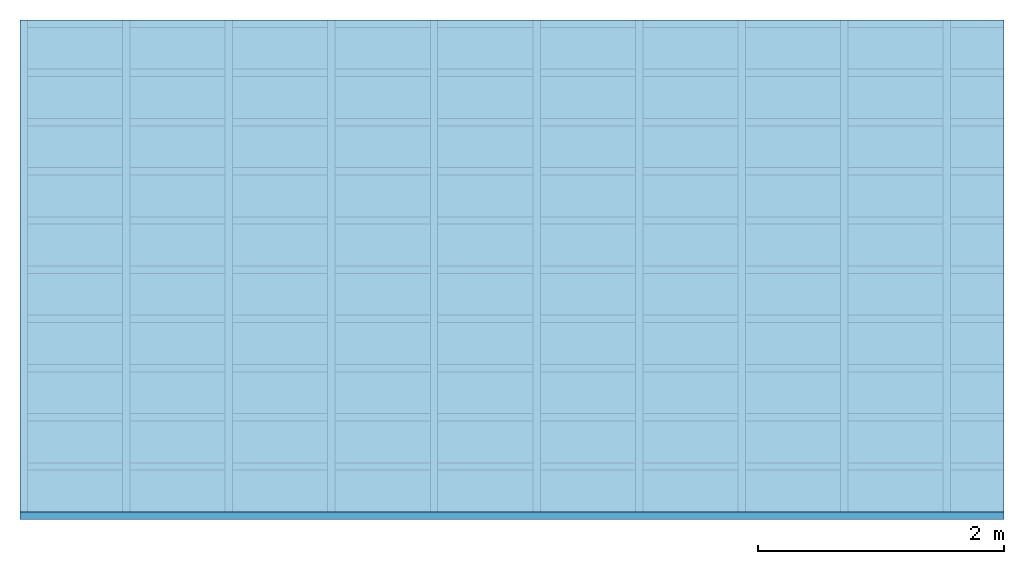
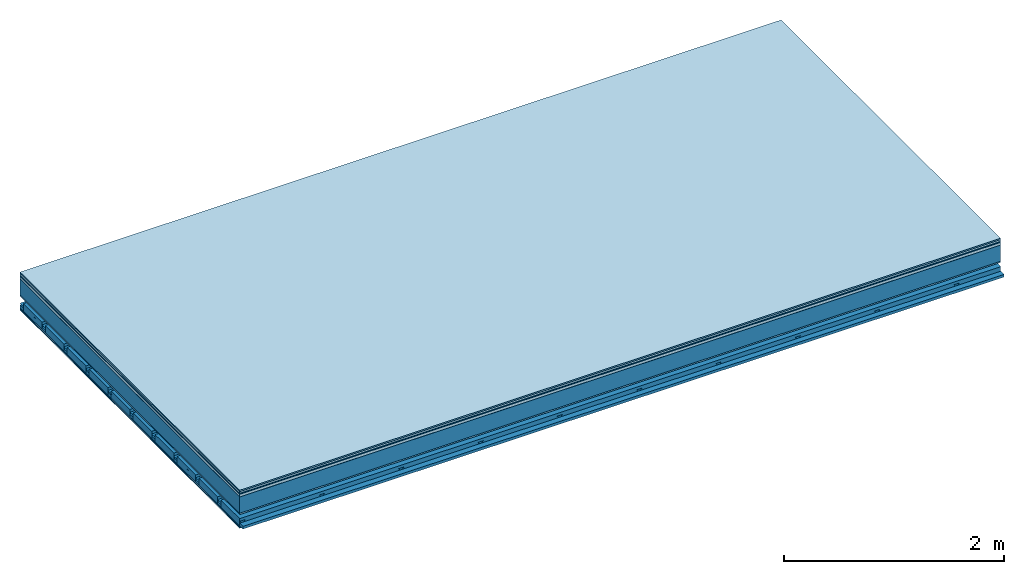
# One storey: 9 plates, 4 members, 1 element without a shape of its own.
"""IFC4 building model written with IfcOpenShell, lengths in metres."""

from ifc_helpers import new_model, si_unit, derived_unit, direction, frame, frame_2d, origin, origin_with_axes, place, context, project, spatial, polyline, rectangle, outline, extrude, material, layer, layer_set, type_object, element, aggregate, save


model = new_model("IFC4")

# Units and contexts
plan_context = context("Plan", 3, precision=1e-05, world=origin(), true_north=direction((0.0, 1.0)))
model_context = context("Model", 3, precision=1e-05, world=origin(), true_north=direction((0.0, 1.0)))
ifc_project = project(units=[si_unit("LENGTHUNIT", "METRE"), derived_unit("SOUNDPRESSUREUNIT", [(si_unit("PRESSUREUNIT", "PASCAL", prefix="MICRO"), 0)]), si_unit("ENERGYUNIT", "JOULE", prefix="MEGA"), si_unit("MASSUNIT", "GRAM", prefix="KILO"), derived_unit("THERMALTRANSMITTANCEUNIT", [(si_unit("POWERUNIT", "WATT"), 1), (si_unit("AREAUNIT", "SQUARE_METRE"), -1), (si_unit("THERMODYNAMICTEMPERATUREUNIT", "KELVIN"), -1)]), derived_unit("AREADENSITYUNIT", [(si_unit("MASSUNIT", "GRAM", prefix="KILO"), 1), (si_unit("AREAUNIT", "SQUARE_METRE"), -1)]), derived_unit("USERDEFINED", [(si_unit("ENERGYUNIT", "JOULE", prefix="MEGA"), 1), (si_unit("AREAUNIT", "SQUARE_METRE"), -1)])], contexts=[plan_context, model_context])

# Site, building, storey
site = spatial("IfcSite", under=ifc_project)
building_placement = place(None, origin())
building = spatial("IfcBuilding", under=site, at=building_placement)
storey_placement = place(building_placement, origin())
storey = spatial("IfcBuildingStorey", under=building, at=storey_placement)

# Slab, members, plates
ifc_material_1 = material(Category="11.013")
ifc_layer_1 = layer(ifc_material_1, 0.015, Name="Flooring")
ifc_material_2 = material(Category="03.007")
ifc_layer_2 = layer(ifc_material_2, 0.02, Name="On-material")
ifc_material_3 = material(Name="Wood fiber generic product", Category="10.009")
ifc_layer_3 = layer(ifc_material_3, 0.01, Name="Impact sound insulation")
ifc_material_4 = material(Name="with broken")
ifc_layer_4 = layer(ifc_material_4, 0.03, Name="on Supporting structure")
ifc_material_5 = material(Name="protection", Category="09.007")
ifc_layer_5 = layer(ifc_material_5, 0.0005, Name="Sub-floor")
ifc_material_6 = material(Name="no composite action")
ifc_layer_6 = layer(ifc_material_6, 0.0, Name="Bond")
ifc_layer_7 = layer(None, 0.18, Name="Supporting structure")
ifc_material_7 = material(Name="of the art")
ifc_layer_8 = layer(ifc_material_7, 0.0, Name="Bond")
ifc_layer_9 = layer(ifc_material_2, 0.015, Name="Lower layer 1")
ifc_layer_10 = layer(None, 0.095, Name="Coupling")
ifc_layer_11 = layer(None, 0.03, Name="Battens / profiles")
ifc_material_8 = material(Name="Plasterboard type A", Category="03.008")
ifc_layer_12 = layer(ifc_material_8, 0.0125, Name="Ceiling covering 1st layer")
ifc_layer_13 = layer(ifc_material_8, 0.0125, Name="Ceiling covering layer 2")
ifc_material_9 = material(Category="04.001")
ifc_layer_14 = layer(ifc_material_9, 0.003, Name="Surface / treatment")
ifc_layer_set = layer_set([ifc_layer_1, ifc_layer_2, ifc_layer_3, ifc_layer_4, ifc_layer_5, ifc_layer_6, ifc_layer_7, ifc_layer_8, ifc_layer_9, ifc_layer_10, ifc_layer_11, ifc_layer_12, ifc_layer_13, ifc_layer_14])
slab_type = type_object("IfcSlabType", Name="A2126", PredefinedType="NOTDEFINED", material=ifc_layer_set)
slab_placement = place(None, frame((0.0, 0.0, 0.0), z_axis=(0.0, 0.0, -1.0), x_axis=(1.0, 0.0, 0.0)))
slab = element("IfcSlab", 1, at=slab_placement, inside=storey, type_object=slab_type, material=ifc_layer_set, Name="Slab #1")
ifc_material_10 = material(Name="Solid timber panel")
member_1_placement = place(slab_placement, origin())
member_1 = element("IfcMember", 2, at=member_1_placement, material=ifc_material_10, Name="Supporting structure", context=plan_context, shape_type="SweptSolid", body=[
    extrude(rectangle(XDim=1.0, YDim=0.18, at=frame_2d((0.5, 0.09), x_axis=(1.0, 0.0))), frame((0.0, 4.0, 0.0755), z_axis=(0.0, -1.0, 0.0), x_axis=(1.0, 0.0, 0.0)), (0.0, 0.0, 1.0), 4.0),
    extrude(rectangle(XDim=1.0, YDim=0.18, at=frame_2d((0.5, 0.09), x_axis=(1.0, 0.0))), frame((1.0, 4.0, 0.0755), z_axis=(0.0, -1.0, 0.0), x_axis=(1.0, 0.0, 0.0)), (0.0, 0.0, 1.0), 4.0),
    extrude(rectangle(XDim=1.0, YDim=0.18, at=frame_2d((0.5, 0.09), x_axis=(1.0, 0.0))), frame((2.0, 4.0, 0.0755), z_axis=(0.0, -1.0, 0.0), x_axis=(1.0, 0.0, 0.0)), (0.0, 0.0, 1.0), 4.0),
    extrude(rectangle(XDim=1.0, YDim=0.18, at=frame_2d((0.5, 0.09), x_axis=(1.0, 0.0))), frame((3.0, 4.0, 0.0755), z_axis=(0.0, -1.0, 0.0), x_axis=(1.0, 0.0, 0.0)), (0.0, 0.0, 1.0), 4.0),
    extrude(rectangle(XDim=1.0, YDim=0.18, at=frame_2d((0.5, 0.09), x_axis=(1.0, 0.0))), frame((4.0, 4.0, 0.0755), z_axis=(0.0, -1.0, 0.0), x_axis=(1.0, 0.0, 0.0)), (0.0, 0.0, 1.0), 4.0),
    extrude(rectangle(XDim=1.0, YDim=0.18, at=frame_2d((0.5, 0.09), x_axis=(1.0, 0.0))), frame((5.0, 4.0, 0.0755), z_axis=(0.0, -1.0, 0.0), x_axis=(1.0, 0.0, 0.0)), (0.0, 0.0, 1.0), 4.0),
    extrude(rectangle(XDim=1.0, YDim=0.18, at=frame_2d((0.5, 0.09), x_axis=(1.0, 0.0))), frame((6.0, 4.0, 0.0755), z_axis=(0.0, -1.0, 0.0), x_axis=(1.0, 0.0, 0.0)), (0.0, 0.0, 1.0), 4.0),
    extrude(rectangle(XDim=1.0, YDim=0.18, at=frame_2d((0.5, 0.09), x_axis=(1.0, 0.0))), frame((7.0, 4.0, 0.0755), z_axis=(0.0, -1.0, 0.0), x_axis=(1.0, 0.0, 0.0)), (0.0, 0.0, 1.0), 4.0),
])
ifc_material_11 = material()
member_2_placement = place(slab_placement, origin())
member_2 = element("IfcMember", 3, at=member_2_placement, material=ifc_material_11, Name="Coupling", context=plan_context, shape_type="SweptSolid", body=[
    extrude(outline(polyline([(0.0, 0.0), (0.06, 0.0), (0.04, 0.02), (0.02, 0.02), (0.0, 0.0)])), frame((0.0, 4.0, 0.3455), z_axis=(0.0, -1.0, 0.0), x_axis=(1.0, 0.0, 0.0)), (0.0, 0.0, 1.0), 4.0),
    extrude(outline(polyline([(0.0, 0.0), (0.06, 0.0), (0.04, 0.02), (0.02, 0.02), (0.0, 0.0)])), frame((0.834, 4.0, 0.3455), z_axis=(0.0, -1.0, 0.0), x_axis=(1.0, 0.0, 0.0)), (0.0, 0.0, 1.0), 4.0),
    extrude(outline(polyline([(0.0, 0.0), (0.06, 0.0), (0.04, 0.02), (0.02, 0.02), (0.0, 0.0)])), frame((1.668, 4.0, 0.3455), z_axis=(0.0, -1.0, 0.0), x_axis=(1.0, 0.0, 0.0)), (0.0, 0.0, 1.0), 4.0),
    extrude(outline(polyline([(0.0, 0.0), (0.06, 0.0), (0.04, 0.02), (0.02, 0.02), (0.0, 0.0)])), frame((2.502, 4.0, 0.3455), z_axis=(0.0, -1.0, 0.0), x_axis=(1.0, 0.0, 0.0)), (0.0, 0.0, 1.0), 4.0),
    extrude(outline(polyline([(0.0, 0.0), (0.06, 0.0), (0.04, 0.02), (0.02, 0.02), (0.0, 0.0)])), frame((3.336, 4.0, 0.3455), z_axis=(0.0, -1.0, 0.0), x_axis=(1.0, 0.0, 0.0)), (0.0, 0.0, 1.0), 4.0),
    extrude(outline(polyline([(0.0, 0.0), (0.06, 0.0), (0.04, 0.02), (0.02, 0.02), (0.0, 0.0)])), frame((4.17, 4.0, 0.3455), z_axis=(0.0, -1.0, 0.0), x_axis=(1.0, 0.0, 0.0)), (0.0, 0.0, 1.0), 4.0),
    extrude(outline(polyline([(0.0, 0.0), (0.06, 0.0), (0.04, 0.02), (0.02, 0.02), (0.0, 0.0)])), frame((5.004, 4.0, 0.3455), z_axis=(0.0, -1.0, 0.0), x_axis=(1.0, 0.0, 0.0)), (0.0, 0.0, 1.0), 4.0),
    extrude(outline(polyline([(0.0, 0.0), (0.06, 0.0), (0.04, 0.02), (0.02, 0.02), (0.0, 0.0)])), frame((5.838, 4.0, 0.3455), z_axis=(0.0, -1.0, 0.0), x_axis=(1.0, 0.0, 0.0)), (0.0, 0.0, 1.0), 4.0),
    extrude(outline(polyline([(0.0, 0.0), (0.06, 0.0), (0.04, 0.02), (0.02, 0.02), (0.0, 0.0)])), frame((6.672, 4.0, 0.3455), z_axis=(0.0, -1.0, 0.0), x_axis=(1.0, 0.0, 0.0)), (0.0, 0.0, 1.0), 4.0),
    extrude(outline(polyline([(0.0, 0.0), (0.06, 0.0), (0.04, 0.02), (0.02, 0.02), (0.0, 0.0)])), frame((7.506, 4.0, 0.3455), z_axis=(0.0, -1.0, 0.0), x_axis=(1.0, 0.0, 0.0)), (0.0, 0.0, 1.0), 4.0),
])
member_3_placement = place(slab_placement, origin())
member_3 = element("IfcMember", 4, at=member_3_placement, material=ifc_material_11, Name="Battens / profiles", context=plan_context, shape_type="SweptSolid", body=[
    extrude(rectangle(XDim=0.06, YDim=0.03, at=frame_2d((0.03, 0.015), x_axis=(1.0, 0.0))), frame((0.0, 0.0, 0.3655), z_axis=(1.0, 0.0, 0.0), x_axis=(0.0, 1.0, 0.0)), (0.0, 0.0, 1.0), 8.0),
    extrude(rectangle(XDim=0.06, YDim=0.03, at=frame_2d((0.03, 0.015), x_axis=(1.0, 0.0))), frame((0.0, 0.4, 0.3655), z_axis=(1.0, 0.0, 0.0), x_axis=(0.0, 1.0, 0.0)), (0.0, 0.0, 1.0), 8.0),
    extrude(rectangle(XDim=0.06, YDim=0.03, at=frame_2d((0.03, 0.015), x_axis=(1.0, 0.0))), frame((0.0, 0.8, 0.3655), z_axis=(1.0, 0.0, 0.0), x_axis=(0.0, 1.0, 0.0)), (0.0, 0.0, 1.0), 8.0),
    extrude(rectangle(XDim=0.06, YDim=0.03, at=frame_2d((0.03, 0.015), x_axis=(1.0, 0.0))), frame((0.0, 1.2, 0.3655), z_axis=(1.0, 0.0, 0.0), x_axis=(0.0, 1.0, 0.0)), (0.0, 0.0, 1.0), 8.0),
    extrude(rectangle(XDim=0.06, YDim=0.03, at=frame_2d((0.03, 0.015), x_axis=(1.0, 0.0))), frame((0.0, 1.6, 0.3655), z_axis=(1.0, 0.0, 0.0), x_axis=(0.0, 1.0, 0.0)), (0.0, 0.0, 1.0), 8.0),
    extrude(rectangle(XDim=0.06, YDim=0.03, at=frame_2d((0.03, 0.015), x_axis=(1.0, 0.0))), frame((0.0, 2.0, 0.3655), z_axis=(1.0, 0.0, 0.0), x_axis=(0.0, 1.0, 0.0)), (0.0, 0.0, 1.0), 8.0),
    extrude(rectangle(XDim=0.06, YDim=0.03, at=frame_2d((0.03, 0.015), x_axis=(1.0, 0.0))), frame((0.0, 2.4, 0.3655), z_axis=(1.0, 0.0, 0.0), x_axis=(0.0, 1.0, 0.0)), (0.0, 0.0, 1.0), 8.0),
    extrude(rectangle(XDim=0.06, YDim=0.03, at=frame_2d((0.03, 0.015), x_axis=(1.0, 0.0))), frame((0.0, 2.8, 0.3655), z_axis=(1.0, 0.0, 0.0), x_axis=(0.0, 1.0, 0.0)), (0.0, 0.0, 1.0), 8.0),
    extrude(rectangle(XDim=0.06, YDim=0.03, at=frame_2d((0.03, 0.015), x_axis=(1.0, 0.0))), frame((0.0, 3.2, 0.3655), z_axis=(1.0, 0.0, 0.0), x_axis=(0.0, 1.0, 0.0)), (0.0, 0.0, 1.0), 8.0),
    extrude(rectangle(XDim=0.06, YDim=0.03, at=frame_2d((0.03, 0.015), x_axis=(1.0, 0.0))), frame((0.0, 3.6, 0.3655), z_axis=(1.0, 0.0, 0.0), x_axis=(0.0, 1.0, 0.0)), (0.0, 0.0, 1.0), 8.0),
    extrude(rectangle(XDim=0.06, YDim=0.03, at=frame_2d((0.03, 0.015), x_axis=(1.0, 0.0))), frame((0.0, 4.0, 0.3655), z_axis=(1.0, 0.0, 0.0), x_axis=(0.0, 1.0, 0.0)), (0.0, 0.0, 1.0), 8.0),
])
ifc_material_12 = material()
member_4_placement = place(slab_placement, origin())
member_4 = element("IfcMember", 5, at=member_4_placement, material=ifc_material_12, Name="Cavity", context=plan_context, shape_type="SweptSolid", body=[
    extrude(rectangle(XDim=0.34, YDim=0.08, at=frame_2d((0.17, 0.04), x_axis=(1.0, 0.0))), frame((0.0, 0.06, 0.3155), z_axis=(1.0, 0.0, 0.0), x_axis=(0.0, 1.0, 0.0)), (0.0, 0.0, 1.0), 8.0),
    extrude(rectangle(XDim=0.34, YDim=0.08, at=frame_2d((0.17, 0.04), x_axis=(1.0, 0.0))), frame((0.0, 0.46, 0.3155), z_axis=(1.0, 0.0, 0.0), x_axis=(0.0, 1.0, 0.0)), (0.0, 0.0, 1.0), 8.0),
    extrude(rectangle(XDim=0.34, YDim=0.08, at=frame_2d((0.17, 0.04), x_axis=(1.0, 0.0))), frame((0.0, 0.86, 0.3155), z_axis=(1.0, 0.0, 0.0), x_axis=(0.0, 1.0, 0.0)), (0.0, 0.0, 1.0), 8.0),
    extrude(rectangle(XDim=0.34, YDim=0.08, at=frame_2d((0.17, 0.04), x_axis=(1.0, 0.0))), frame((0.0, 1.26, 0.3155), z_axis=(1.0, 0.0, 0.0), x_axis=(0.0, 1.0, 0.0)), (0.0, 0.0, 1.0), 8.0),
    extrude(rectangle(XDim=0.34, YDim=0.08, at=frame_2d((0.17, 0.04), x_axis=(1.0, 0.0))), frame((0.0, 1.66, 0.3155), z_axis=(1.0, 0.0, 0.0), x_axis=(0.0, 1.0, 0.0)), (0.0, 0.0, 1.0), 8.0),
    extrude(rectangle(XDim=0.34, YDim=0.08, at=frame_2d((0.17, 0.04), x_axis=(1.0, 0.0))), frame((0.0, 2.06, 0.3155), z_axis=(1.0, 0.0, 0.0), x_axis=(0.0, 1.0, 0.0)), (0.0, 0.0, 1.0), 8.0),
    extrude(rectangle(XDim=0.34, YDim=0.08, at=frame_2d((0.17, 0.04), x_axis=(1.0, 0.0))), frame((0.0, 2.46, 0.3155), z_axis=(1.0, 0.0, 0.0), x_axis=(0.0, 1.0, 0.0)), (0.0, 0.0, 1.0), 8.0),
    extrude(rectangle(XDim=0.34, YDim=0.08, at=frame_2d((0.17, 0.04), x_axis=(1.0, 0.0))), frame((0.0, 2.86, 0.3155), z_axis=(1.0, 0.0, 0.0), x_axis=(0.0, 1.0, 0.0)), (0.0, 0.0, 1.0), 8.0),
    extrude(rectangle(XDim=0.34, YDim=0.08, at=frame_2d((0.17, 0.04), x_axis=(1.0, 0.0))), frame((0.0, 3.26, 0.3155), z_axis=(1.0, 0.0, 0.0), x_axis=(0.0, 1.0, 0.0)), (0.0, 0.0, 1.0), 8.0),
    extrude(rectangle(XDim=0.34, YDim=0.08, at=frame_2d((0.17, 0.04), x_axis=(1.0, 0.0))), frame((0.0, 3.66, 0.3155), z_axis=(1.0, 0.0, 0.0), x_axis=(0.0, 1.0, 0.0)), (0.0, 0.0, 1.0), 8.0),
])
plate_1_placement = place(slab_placement, origin())
plate_1 = element("IfcPlate", 6, at=plate_1_placement, material=ifc_material_1, Name="Flooring", context=plan_context, shape_type="SweptSolid", body=[
    extrude(rectangle(XDim=8.0, YDim=4.0, at=frame_2d((4.0, 2.0), x_axis=(1.0, 0.0))), origin_with_axes(), (0.0, 0.0, 1.0), 0.015),
])
plate_2_placement = place(slab_placement, origin())
plate_2 = element("IfcPlate", 7, at=plate_2_placement, material=ifc_material_2, Name="On-material", context=plan_context, shape_type="SweptSolid", body=[
    extrude(rectangle(XDim=8.0, YDim=4.0, at=frame_2d((4.0, 2.0), x_axis=(1.0, 0.0))), frame((0.0, 0.0, 0.015), z_axis=(0.0, 0.0, 1.0), x_axis=(1.0, 0.0, 0.0)), (0.0, 0.0, 1.0), 0.02),
])
plate_3_placement = place(slab_placement, origin())
plate_3 = element("IfcPlate", 8, at=plate_3_placement, material=ifc_material_3, Name="Impact sound insulation", context=plan_context, shape_type="SweptSolid", body=[
    extrude(rectangle(XDim=8.0, YDim=4.0, at=frame_2d((4.0, 2.0), x_axis=(1.0, 0.0))), frame((0.0, 0.0, 0.035), z_axis=(0.0, 0.0, 1.0), x_axis=(1.0, 0.0, 0.0)), (0.0, 0.0, 1.0), 0.01),
])
plate_4_placement = place(slab_placement, origin())
plate_4 = element("IfcPlate", 9, at=plate_4_placement, material=ifc_material_4, Name="on Supporting structure", context=plan_context, shape_type="SweptSolid", body=[
    extrude(rectangle(XDim=8.0, YDim=4.0, at=frame_2d((4.0, 2.0), x_axis=(1.0, 0.0))), frame((0.0, 0.0, 0.045), z_axis=(0.0, 0.0, 1.0), x_axis=(1.0, 0.0, 0.0)), (0.0, 0.0, 1.0), 0.03),
])
plate_5_placement = place(slab_placement, origin())
plate_5 = element("IfcPlate", 10, at=plate_5_placement, material=ifc_material_5, Name="Sub-floor", context=plan_context, shape_type="SweptSolid", body=[
    extrude(rectangle(XDim=8.0, YDim=4.0, at=frame_2d((4.0, 2.0), x_axis=(1.0, 0.0))), frame((0.0, 0.0, 0.075), z_axis=(0.0, 0.0, 1.0), x_axis=(1.0, 0.0, 0.0)), (0.0, 0.0, 1.0), 0.0005),
])
plate_6_placement = place(slab_placement, origin())
plate_6 = element("IfcPlate", 11, at=plate_6_placement, material=ifc_material_2, Name="Lower layer 1", context=plan_context, shape_type="SweptSolid", body=[
    extrude(rectangle(XDim=8.0, YDim=4.0, at=frame_2d((4.0, 2.0), x_axis=(1.0, 0.0))), frame((0.0, 0.0, 0.2555), z_axis=(0.0, 0.0, 1.0), x_axis=(1.0, 0.0, 0.0)), (0.0, 0.0, 1.0), 0.015),
])
plate_7_placement = place(slab_placement, origin())
plate_7 = element("IfcPlate", 12, at=plate_7_placement, material=ifc_material_8, Name="Ceiling covering 1st layer", context=plan_context, shape_type="SweptSolid", body=[
    extrude(rectangle(XDim=8.0, YDim=4.0, at=frame_2d((4.0, 2.0), x_axis=(1.0, 0.0))), frame((0.0, 0.0, 0.3955), z_axis=(0.0, 0.0, 1.0), x_axis=(1.0, 0.0, 0.0)), (0.0, 0.0, 1.0), 0.0125),
])
plate_8_placement = place(slab_placement, origin())
plate_8 = element("IfcPlate", 13, at=plate_8_placement, material=ifc_material_8, Name="Ceiling covering layer 2", context=plan_context, shape_type="SweptSolid", body=[
    extrude(rectangle(XDim=8.0, YDim=4.0, at=frame_2d((4.0, 2.0), x_axis=(1.0, 0.0))), frame((0.0, 0.0, 0.408), z_axis=(0.0, 0.0, 1.0), x_axis=(1.0, 0.0, 0.0)), (0.0, 0.0, 1.0), 0.0125),
])
plate_9_placement = place(slab_placement, origin())
plate_9 = element("IfcPlate", 14, at=plate_9_placement, material=ifc_material_9, Name="Surface / treatment", context=plan_context, shape_type="SweptSolid", body=[
    extrude(rectangle(XDim=8.0, YDim=4.0, at=frame_2d((4.0, 2.0), x_axis=(1.0, 0.0))), frame((0.0, 0.0, 0.4205), z_axis=(0.0, 0.0, 1.0), x_axis=(1.0, 0.0, 0.0)), (0.0, 0.0, 1.0), 0.003),
])
aggregate(slab, [plate_1, plate_2, plate_3, plate_4, plate_5, member_1, plate_6, member_2, member_3, member_4, plate_7, plate_8, plate_9])

save(model, "model.ifc")
